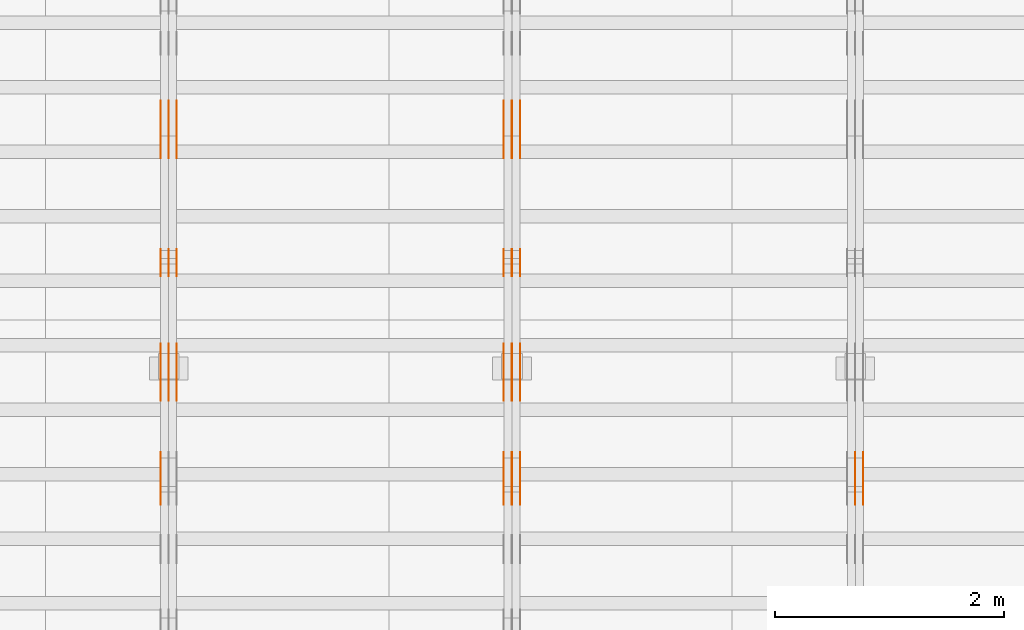
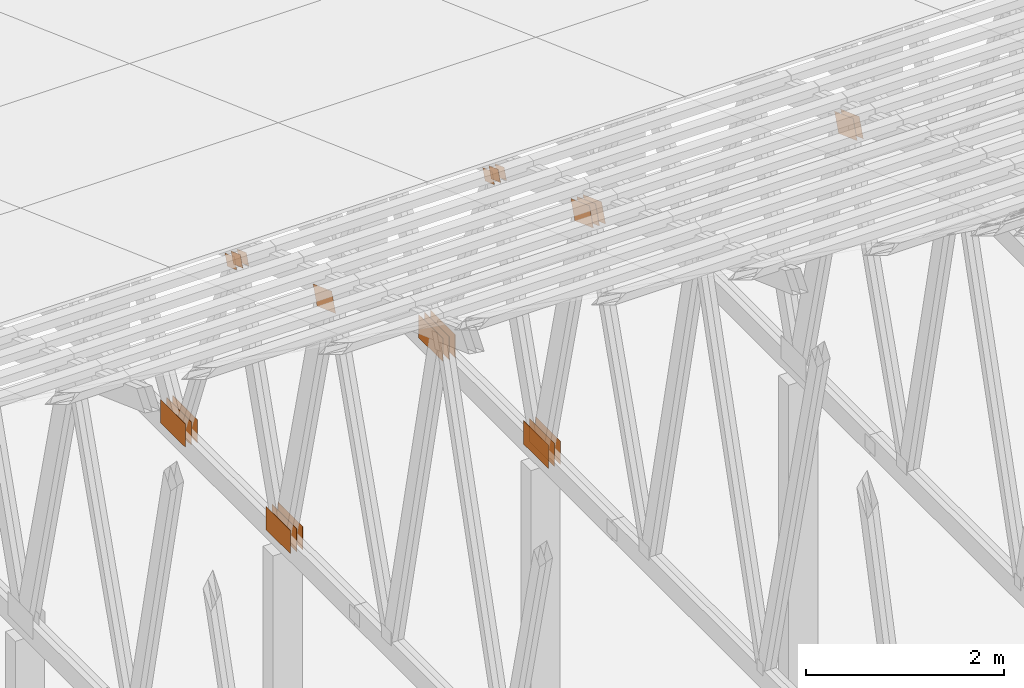
# One storey, part 121 of 189: 31 proxies.
"""IFC2X3 building model written with IfcOpenShell, lengths in millimetres."""

from ifc_helpers import new_model, entity, si_unit, converted_unit, derived_unit, direction, frame, origin, origin_2d_with_axis, place, context, subcontext, project, spatial, polyline, rectangle, outline, extrude, source, transform, mapped, material, type_object, type_shapes, element, save


model = new_model("IFC2X3")

# Units and contexts
model_context = context("Model", 3, precision=0.01, world=origin(), true_north=direction((6.12303176911189e-17, 1.0)))
body_context = subcontext(model_context, "Body", "Model", "MODEL_VIEW")
ifc_project = project(units=[si_unit("LENGTHUNIT", "METRE", prefix="MILLI"), si_unit("AREAUNIT", "SQUARE_METRE"), si_unit("VOLUMEUNIT", "CUBIC_METRE"), converted_unit("PLANEANGLEUNIT", "DEGREE", entity("IfcRatioMeasure", 0.0174532925199433), si_unit("PLANEANGLEUNIT", "RADIAN"), dimensions=[0, 0, 0, 0, 0, 0, 0]), si_unit("MASSUNIT", "GRAM", prefix="KILO"), derived_unit("MASSDENSITYUNIT", [(si_unit("MASSUNIT", "GRAM", prefix="KILO"), 1), (si_unit("LENGTHUNIT", "METRE"), -3)]), si_unit("TIMEUNIT", "SECOND"), si_unit("FREQUENCYUNIT", "HERTZ"), si_unit("THERMODYNAMICTEMPERATUREUNIT", "DEGREE_CELSIUS"), derived_unit("THERMALTRANSMITTANCEUNIT", [(si_unit("MASSUNIT", "GRAM", prefix="KILO"), 1), (si_unit("THERMODYNAMICTEMPERATUREUNIT", "KELVIN"), -1), (si_unit("TIMEUNIT", "SECOND"), -3)]), derived_unit("VOLUMETRICFLOWRATEUNIT", [(si_unit("LENGTHUNIT", "METRE"), 3), (si_unit("TIMEUNIT", "SECOND"), -1)]), si_unit("ELECTRICCURRENTUNIT", "AMPERE"), si_unit("ELECTRICVOLTAGEUNIT", "VOLT"), si_unit("POWERUNIT", "WATT"), si_unit("FORCEUNIT", "NEWTON"), si_unit("ILLUMINANCEUNIT", "LUX"), si_unit("LUMINOUSFLUXUNIT", "LUMEN"), si_unit("LUMINOUSINTENSITYUNIT", "CANDELA"), derived_unit("USERDEFINED", [(si_unit("MASSUNIT", "GRAM", prefix="KILO"), -1), (si_unit("LENGTHUNIT", "METRE"), -2), (si_unit("TIMEUNIT", "SECOND"), 3), (si_unit("LUMINOUSFLUXUNIT", "LUMEN"), 1)]), derived_unit("LINEARVELOCITYUNIT", [(si_unit("LENGTHUNIT", "METRE"), 1), (si_unit("TIMEUNIT", "SECOND"), -1)]), si_unit("PRESSUREUNIT", "PASCAL"), derived_unit("USERDEFINED", [(si_unit("LENGTHUNIT", "METRE"), -2), (si_unit("MASSUNIT", "GRAM", prefix="KILO"), 1), (si_unit("TIMEUNIT", "SECOND"), -2)])], contexts=[model_context])

# Site, building, storey
site_placement = place(None, origin())
site = spatial("IfcSite", under=ifc_project, at=site_placement, CompositionType="ELEMENT")
building_placement = place(site_placement, origin())
building = spatial("IfcBuilding", under=site, at=building_placement, CompositionType="ELEMENT")
storey_placement = place(building_placement, origin())
storey = spatial("IfcBuildingStorey", under=building, at=storey_placement, Name="Default", CompositionType="ELEMENT", Elevation=0.0)

# Proxies
ifc_material_1 = material(Name="IfcSurfaceStyle #123864")
building_element_proxy_type_1 = type_object("IfcBuildingElementProxyType", PredefinedType="NOTDEFINED", material=ifc_material_1)
shared_shape_1 = source(origin(), body_context, "Body", "SweptSolid", [
    extrude(outline(polyline([(-200.000344770935, -119.999765965113), (199.999582244654, -119.999765965113), (200.000344770935, 119.999765965113), (-199.999582244653, 119.999765965113), (-200.000344770935, -119.999765965113)])), frame((200.000344770935, 119.999990805307, 0.0), z_axis=(0.0, 0.0, 1.0), x_axis=(-1.0, 0.0, 0.0)), (0.0, 0.0, 1.0), 1.29999999999999),
])
type_shapes(building_element_proxy_type_1, [shared_shape_1])
proxy_1_placement = place(building_placement, frame((21301.3, 19620.1777846684, 3837.77137841443), z_axis=(-1.0, 0.0, 0.0), x_axis=(0.0, 0.939692620785908, -0.342020143325669)))
element("IfcBuildingElementProxy", 1, at=proxy_1_placement, inside=storey, type_object=building_element_proxy_type_1, material=ifc_material_1, context=body_context, shape_type="MappedRepresentation", body=[
    mapped(shared_shape_1, transform((0.0, 0.0, 0.0), scale=1.0)),
])
ifc_material_2 = material(Name="IfcSurfaceStyle #123807")
building_element_proxy_type_2 = type_object("IfcBuildingElementProxyType", PredefinedType="NOTDEFINED", material=ifc_material_2)
shared_shape_2 = source(origin(), body_context, "Body", "SweptSolid", [
    extrude(outline(polyline([(-200.000344770935, -119.999765965113), (199.999582244654, -119.999765965113), (200.000344770935, 119.999765965113), (-199.999582244653, 119.999765965113), (-200.000344770935, -119.999765965113)])), frame((200.000344770935, 119.999990805307, 0.0), z_axis=(0.0, 0.0, 1.0), x_axis=(-1.0, 0.0, 0.0)), (0.0, 0.0, 1.0), 1.29999999999997),
])
type_shapes(building_element_proxy_type_2, [shared_shape_2])
proxy_2_placement = place(building_placement, frame((21230.0, 19620.1777846684, 3837.77137841443), z_axis=(-1.0, 0.0, 0.0), x_axis=(0.0, 0.939692620785908, -0.342020143325669)))
element("IfcBuildingElementProxy", 2, at=proxy_2_placement, inside=storey, type_object=building_element_proxy_type_2, material=ifc_material_2, context=body_context, shape_type="MappedRepresentation", body=[
    mapped(shared_shape_2, transform((0.0, 0.0, 0.0), scale=1.0)),
])
ifc_material_3 = material(Name="IfcSurfaceStyle #108074")
building_element_proxy_type_3 = type_object("IfcBuildingElementProxyType", PredefinedType="NOTDEFINED", material=ifc_material_3)
shared_shape_3 = source(origin(), body_context, "Body", "SweptSolid", [
    extrude(outline(polyline([(-200.000344770935, -119.999765965113), (199.999582244654, -119.999765965113), (200.000344770935, 119.999765965113), (-199.999582244653, 119.999765965113), (-200.000344770935, -119.999765965113)])), frame((200.000344770935, 119.999990805307, 0.0), z_axis=(0.0, 0.0, 1.0), x_axis=(-1.0, 0.0, 0.0)), (0.0, 0.0, 1.0), 1.29999999999999),
])
type_shapes(building_element_proxy_type_3, [shared_shape_3])
proxy_3_placement = place(building_placement, frame((18301.3, 19620.1777846684, 3837.77137841443), z_axis=(-1.0, 0.0, 0.0), x_axis=(0.0, 0.939692620785908, -0.342020143325669)))
element("IfcBuildingElementProxy", 3, at=proxy_3_placement, inside=storey, type_object=building_element_proxy_type_3, material=ifc_material_3, context=body_context, shape_type="MappedRepresentation", body=[
    mapped(shared_shape_3, transform((0.0, 0.0, 0.0), scale=1.0)),
])
ifc_material_4 = material(Name="IfcSurfaceStyle #108017")
building_element_proxy_type_4 = type_object("IfcBuildingElementProxyType", PredefinedType="NOTDEFINED", material=ifc_material_4)
shared_shape_4 = source(origin(), body_context, "Body", "SweptSolid", [
    extrude(outline(polyline([(-200.000344770935, -119.999765965113), (199.999582244654, -119.999765965113), (200.000344770935, 119.999765965113), (-199.999582244653, 119.999765965113), (-200.000344770935, -119.999765965113)])), frame((200.000344770935, 119.999990805307, 0.0), z_axis=(0.0, 0.0, 1.0), x_axis=(-1.0, 0.0, 0.0)), (0.0, 0.0, 1.0), 1.29999999999997),
])
type_shapes(building_element_proxy_type_4, [shared_shape_4])
proxy_4_placement = place(building_placement, frame((18230.0, 19620.1777846684, 3837.77137841443), z_axis=(-1.0, 0.0, 0.0), x_axis=(0.0, 0.939692620785908, -0.342020143325669)))
element("IfcBuildingElementProxy", 4, at=proxy_4_placement, inside=storey, type_object=building_element_proxy_type_4, material=ifc_material_4, context=body_context, shape_type="MappedRepresentation", body=[
    mapped(shared_shape_4, transform((0.0, 0.0, 0.0), scale=1.0)),
])
ifc_material_5 = material(Name="IfcSurfaceStyle #107960")
building_element_proxy_type_5 = type_object("IfcBuildingElementProxyType", PredefinedType="NOTDEFINED", material=ifc_material_5)
shared_shape_5 = source(origin(), body_context, "Body", "SweptSolid", [
    extrude(outline(polyline([(-200.000344770935, -119.999765965113), (199.999582244654, -119.999765965113), (200.000344770935, 119.999765965113), (-199.999582244653, 119.999765965113), (-200.000344770935, -119.999765965113)])), frame((200.000344770935, 119.999990805307, 0.0), z_axis=(0.0, 0.0, 1.0), x_axis=(-1.0, 0.0, 0.0)), (0.0, 0.0, 1.0), 1.29999999999997),
])
type_shapes(building_element_proxy_type_5, [shared_shape_5])
proxy_5_placement = place(building_placement, frame((18231.3, 19620.1777846684, 3837.77137841443), z_axis=(-1.0, 0.0, 0.0), x_axis=(0.0, 0.939692620785908, -0.342020143325669)))
element("IfcBuildingElementProxy", 5, at=proxy_5_placement, inside=storey, type_object=building_element_proxy_type_5, material=ifc_material_5, context=body_context, shape_type="MappedRepresentation", body=[
    mapped(shared_shape_5, transform((0.0, 0.0, 0.0), scale=1.0)),
])
ifc_material_6 = material(Name="IfcSurfaceStyle #107903")
building_element_proxy_type_6 = type_object("IfcBuildingElementProxyType", PredefinedType="NOTDEFINED", material=ifc_material_6)
shared_shape_6 = source(origin(), body_context, "Body", "SweptSolid", [
    extrude(outline(polyline([(-200.000344770935, -119.999765965113), (199.999582244654, -119.999765965113), (200.000344770935, 119.999765965113), (-199.999582244653, 119.999765965113), (-200.000344770935, -119.999765965113)])), frame((200.000344770935, 119.999990805307, 0.0), z_axis=(0.0, 0.0, 1.0), x_axis=(-1.0, 0.0, 0.0)), (0.0, 0.0, 1.0), 1.29999999999998),
])
type_shapes(building_element_proxy_type_6, [shared_shape_6])
proxy_6_placement = place(building_placement, frame((18160.0, 19620.1777846684, 3837.77137841443), z_axis=(-1.0, 0.0, 0.0), x_axis=(0.0, 0.939692620785908, -0.342020143325669)))
element("IfcBuildingElementProxy", 6, at=proxy_6_placement, inside=storey, type_object=building_element_proxy_type_6, material=ifc_material_6, context=body_context, shape_type="MappedRepresentation", body=[
    mapped(shared_shape_6, transform((0.0, 0.0, 0.0), scale=1.0)),
])
ifc_material_7 = material(Name="IfcSurfaceStyle #107846")
building_element_proxy_type_7 = type_object("IfcBuildingElementProxyType", PredefinedType="NOTDEFINED", material=ifc_material_7)
shared_shape_7 = source(origin(), body_context, "Body", "SweptSolid", [
    extrude(rectangle(XDim=500.0, YDim=288.0, at=origin_2d_with_axis()), frame((250.0, 144.0, 0.0), z_axis=(0.0, 0.0, 1.0), x_axis=(-1.0, 0.0, 0.0)), (0.0, 0.0, 1.0), 1.29999999999998),
])
type_shapes(building_element_proxy_type_7, [shared_shape_7])
proxy_7_placement = place(building_placement, frame((18301.3, 20948.0908203125, 101.0), z_axis=(-1.0, 0.0, 0.0), x_axis=(0.0, -1.0, 0.0)))
element("IfcBuildingElementProxy", 7, at=proxy_7_placement, inside=storey, type_object=building_element_proxy_type_7, material=ifc_material_7, context=body_context, shape_type="MappedRepresentation", body=[
    mapped(shared_shape_7, transform((0.0, 0.0, 0.0), scale=1.0)),
])
ifc_material_8 = material(Name="IfcSurfaceStyle #107789")
building_element_proxy_type_8 = type_object("IfcBuildingElementProxyType", PredefinedType="NOTDEFINED", material=ifc_material_8)
shared_shape_8 = source(origin(), body_context, "Body", "SweptSolid", [
    extrude(rectangle(XDim=500.0, YDim=288.0, at=origin_2d_with_axis()), frame((250.0, 144.0, 0.0), z_axis=(0.0, 0.0, 1.0), x_axis=(-1.0, 0.0, 0.0)), (0.0, 0.0, 1.0), 1.29999999999997),
])
type_shapes(building_element_proxy_type_8, [shared_shape_8])
proxy_8_placement = place(building_placement, frame((18230.0, 20948.0908203125, 101.0), z_axis=(-1.0, 0.0, 0.0), x_axis=(0.0, -1.0, 0.0)))
element("IfcBuildingElementProxy", 8, at=proxy_8_placement, inside=storey, type_object=building_element_proxy_type_8, material=ifc_material_8, context=body_context, shape_type="MappedRepresentation", body=[
    mapped(shared_shape_8, transform((0.0, 0.0, 0.0), scale=1.0)),
])
ifc_material_9 = material(Name="IfcSurfaceStyle #107732")
building_element_proxy_type_9 = type_object("IfcBuildingElementProxyType", PredefinedType="NOTDEFINED", material=ifc_material_9)
shared_shape_9 = source(origin(), body_context, "Body", "SweptSolid", [
    extrude(rectangle(XDim=500.0, YDim=288.0, at=origin_2d_with_axis()), frame((250.0, 144.0, 0.0), z_axis=(0.0, 0.0, 1.0), x_axis=(-1.0, 0.0, 0.0)), (0.0, 0.0, 1.0), 1.29999999999997),
])
type_shapes(building_element_proxy_type_9, [shared_shape_9])
proxy_9_placement = place(building_placement, frame((18231.3, 20948.0908203125, 101.0), z_axis=(-1.0, 0.0, 0.0), x_axis=(0.0, -1.0, 0.0)))
element("IfcBuildingElementProxy", 9, at=proxy_9_placement, inside=storey, type_object=building_element_proxy_type_9, material=ifc_material_9, context=body_context, shape_type="MappedRepresentation", body=[
    mapped(shared_shape_9, transform((0.0, 0.0, 0.0), scale=1.0)),
])
ifc_material_10 = material(Name="IfcSurfaceStyle #107675")
building_element_proxy_type_10 = type_object("IfcBuildingElementProxyType", PredefinedType="NOTDEFINED", material=ifc_material_10)
shared_shape_10 = source(origin(), body_context, "Body", "SweptSolid", [
    extrude(rectangle(XDim=500.0, YDim=288.0, at=origin_2d_with_axis()), frame((250.0, 144.0, 0.0), z_axis=(0.0, 0.0, 1.0), x_axis=(-1.0, 0.0, 0.0)), (0.0, 0.0, 1.0), 1.29999999999997),
])
type_shapes(building_element_proxy_type_10, [shared_shape_10])
proxy_10_placement = place(building_placement, frame((18160.0, 20948.0908203125, 101.0), z_axis=(-1.0, 0.0, 0.0), x_axis=(0.0, -1.0, 0.0)))
element("IfcBuildingElementProxy", 10, at=proxy_10_placement, inside=storey, type_object=building_element_proxy_type_10, material=ifc_material_10, context=body_context, shape_type="MappedRepresentation", body=[
    mapped(shared_shape_10, transform((0.0, 0.0, 0.0), scale=1.0)),
])
ifc_material_11 = material(Name="IfcSurfaceStyle #107162")
building_element_proxy_type_11 = type_object("IfcBuildingElementProxyType", PredefinedType="NOTDEFINED", material=ifc_material_11)
shared_shape_11 = source(origin(), body_context, "Body", "SweptSolid", [
    extrude(outline(polyline([(-100.000279336925, -71.9999636698844), (100.000143005157, -71.9999636698844), (100.00004991978, 71.9999636698844), (-99.9999135880125, 71.9999636698845), (-100.000279336925, -71.9999636698844)])), frame((100.000143005157, 72.0001110824169, 0.0), z_axis=(0.0, 0.0, 1.0), x_axis=(-1.0, 0.0, 0.0)), (0.0, 0.0, 1.0), 1.3),
])
type_shapes(building_element_proxy_type_11, [shared_shape_11])
proxy_11_placement = place(building_placement, frame((18301.3, 21584.0819808932, 3071.51551466861), z_axis=(-1.0, 0.0, 0.0), x_axis=(0.0, 0.939692620785908, -0.342020143325669)))
element("IfcBuildingElementProxy", 11, at=proxy_11_placement, inside=storey, type_object=building_element_proxy_type_11, material=ifc_material_11, context=body_context, shape_type="MappedRepresentation", body=[
    mapped(shared_shape_11, transform((0.0, 0.0, 0.0), scale=1.0)),
])
ifc_material_12 = material(Name="IfcSurfaceStyle #107105")
building_element_proxy_type_12 = type_object("IfcBuildingElementProxyType", PredefinedType="NOTDEFINED", material=ifc_material_12)
shared_shape_12 = source(origin(), body_context, "Body", "SweptSolid", [
    extrude(outline(polyline([(-100.000279336925, -71.9999636698844), (100.000143005157, -71.9999636698844), (100.00004991978, 71.9999636698844), (-99.9999135880125, 71.9999636698845), (-100.000279336925, -71.9999636698844)])), frame((100.000143005157, 72.0001110824169, 0.0), z_axis=(0.0, 0.0, 1.0), x_axis=(-1.0, 0.0, 0.0)), (0.0, 0.0, 1.0), 1.29999999999998),
])
type_shapes(building_element_proxy_type_12, [shared_shape_12])
proxy_12_placement = place(building_placement, frame((18230.0, 21584.0819808932, 3071.51551466861), z_axis=(-1.0, 0.0, 0.0), x_axis=(0.0, 0.939692620785908, -0.342020143325669)))
element("IfcBuildingElementProxy", 12, at=proxy_12_placement, inside=storey, type_object=building_element_proxy_type_12, material=ifc_material_12, context=body_context, shape_type="MappedRepresentation", body=[
    mapped(shared_shape_12, transform((0.0, 0.0, 0.0), scale=1.0)),
])
ifc_material_13 = material(Name="IfcSurfaceStyle #107048")
building_element_proxy_type_13 = type_object("IfcBuildingElementProxyType", PredefinedType="NOTDEFINED", material=ifc_material_13)
shared_shape_13 = source(origin(), body_context, "Body", "SweptSolid", [
    extrude(outline(polyline([(-100.000279336925, -71.9999636698844), (100.000143005157, -71.9999636698844), (100.00004991978, 71.9999636698844), (-99.9999135880125, 71.9999636698845), (-100.000279336925, -71.9999636698844)])), frame((100.000143005157, 72.0001110824169, 0.0), z_axis=(0.0, 0.0, 1.0), x_axis=(-1.0, 0.0, 0.0)), (0.0, 0.0, 1.0), 1.29999999999998),
])
type_shapes(building_element_proxy_type_13, [shared_shape_13])
proxy_13_placement = place(building_placement, frame((18231.3, 21584.0819808932, 3071.51551466861), z_axis=(-1.0, 0.0, 0.0), x_axis=(0.0, 0.939692620785908, -0.342020143325669)))
element("IfcBuildingElementProxy", 13, at=proxy_13_placement, inside=storey, type_object=building_element_proxy_type_13, material=ifc_material_13, context=body_context, shape_type="MappedRepresentation", body=[
    mapped(shared_shape_13, transform((0.0, 0.0, 0.0), scale=1.0)),
])
ifc_material_14 = material(Name="IfcSurfaceStyle #106991")
building_element_proxy_type_14 = type_object("IfcBuildingElementProxyType", PredefinedType="NOTDEFINED", material=ifc_material_14)
shared_shape_14 = source(origin(), body_context, "Body", "SweptSolid", [
    extrude(outline(polyline([(-100.000279336925, -71.9999636698844), (100.000143005157, -71.9999636698844), (100.00004991978, 71.9999636698844), (-99.9999135880125, 71.9999636698845), (-100.000279336925, -71.9999636698844)])), frame((100.000143005157, 72.0001110824169, 0.0), z_axis=(0.0, 0.0, 1.0), x_axis=(-1.0, 0.0, 0.0)), (0.0, 0.0, 1.0), 1.29999999999999),
])
type_shapes(building_element_proxy_type_14, [shared_shape_14])
proxy_14_placement = place(building_placement, frame((18160.0, 21584.0819808932, 3071.51551466861), z_axis=(-1.0, 0.0, 0.0), x_axis=(0.0, 0.939692620785908, -0.342020143325669)))
element("IfcBuildingElementProxy", 14, at=proxy_14_placement, inside=storey, type_object=building_element_proxy_type_14, material=ifc_material_14, context=body_context, shape_type="MappedRepresentation", body=[
    mapped(shared_shape_14, transform((0.0, 0.0, 0.0), scale=1.0)),
])
ifc_material_15 = material(Name="IfcSurfaceStyle #106934")
building_element_proxy_type_15 = type_object("IfcBuildingElementProxyType", PredefinedType="NOTDEFINED", material=ifc_material_15)
shared_shape_15 = source(origin(), body_context, "Body", "SweptSolid", [
    extrude(rectangle(XDim=500.0, YDim=288.000007629395, at=origin_2d_with_axis()), frame((250.000021301719, 144.000006357829, 0.0), z_axis=(0.0, 0.0, 1.0), x_axis=(-1.0, 0.0, 0.0)), (0.0, 0.0, 1.0), 1.29999999999998),
])
type_shapes(building_element_proxy_type_15, [shared_shape_15])
proxy_15_placement = place(building_placement, frame((18301.3, 23069.1650603642, 127.333333333333), z_axis=(-1.0, 0.0, 0.0), x_axis=(0.0, -1.0, 0.0)))
element("IfcBuildingElementProxy", 15, at=proxy_15_placement, inside=storey, type_object=building_element_proxy_type_15, material=ifc_material_15, context=body_context, shape_type="MappedRepresentation", body=[
    mapped(shared_shape_15, transform((0.0, 0.0, 0.0), scale=1.0)),
])
ifc_material_16 = material(Name="IfcSurfaceStyle #106877")
building_element_proxy_type_16 = type_object("IfcBuildingElementProxyType", PredefinedType="NOTDEFINED", material=ifc_material_16)
shared_shape_16 = source(origin(), body_context, "Body", "SweptSolid", [
    extrude(rectangle(XDim=500.0, YDim=288.000007629395, at=origin_2d_with_axis()), frame((250.000021301719, 144.000006357829, 0.0), z_axis=(0.0, 0.0, 1.0), x_axis=(-1.0, 0.0, 0.0)), (0.0, 0.0, 1.0), 1.29999999999997),
])
type_shapes(building_element_proxy_type_16, [shared_shape_16])
proxy_16_placement = place(building_placement, frame((18230.0, 23069.1650603642, 127.333333333333), z_axis=(-1.0, 0.0, 0.0), x_axis=(0.0, -1.0, 0.0)))
element("IfcBuildingElementProxy", 16, at=proxy_16_placement, inside=storey, type_object=building_element_proxy_type_16, material=ifc_material_16, context=body_context, shape_type="MappedRepresentation", body=[
    mapped(shared_shape_16, transform((0.0, 0.0, 0.0), scale=1.0)),
])
ifc_material_17 = material(Name="IfcSurfaceStyle #106820")
building_element_proxy_type_17 = type_object("IfcBuildingElementProxyType", PredefinedType="NOTDEFINED", material=ifc_material_17)
shared_shape_17 = source(origin(), body_context, "Body", "SweptSolid", [
    extrude(rectangle(XDim=500.0, YDim=288.000007629395, at=origin_2d_with_axis()), frame((250.000021301719, 144.000006357829, 0.0), z_axis=(0.0, 0.0, 1.0), x_axis=(-1.0, 0.0, 0.0)), (0.0, 0.0, 1.0), 1.29999999999997),
])
type_shapes(building_element_proxy_type_17, [shared_shape_17])
proxy_17_placement = place(building_placement, frame((18231.3, 23069.1650603642, 127.333333333333), z_axis=(-1.0, 0.0, 0.0), x_axis=(0.0, -1.0, 0.0)))
element("IfcBuildingElementProxy", 17, at=proxy_17_placement, inside=storey, type_object=building_element_proxy_type_17, material=ifc_material_17, context=body_context, shape_type="MappedRepresentation", body=[
    mapped(shared_shape_17, transform((0.0, 0.0, 0.0), scale=1.0)),
])
ifc_material_18 = material(Name="IfcSurfaceStyle #106763")
building_element_proxy_type_18 = type_object("IfcBuildingElementProxyType", PredefinedType="NOTDEFINED", material=ifc_material_18)
shared_shape_18 = source(origin(), body_context, "Body", "SweptSolid", [
    extrude(rectangle(XDim=500.0, YDim=288.000007629395, at=origin_2d_with_axis()), frame((250.000021301719, 144.000006357829, 0.0), z_axis=(0.0, 0.0, 1.0), x_axis=(-1.0, 0.0, 0.0)), (0.0, 0.0, 1.0), 1.29999999999997),
])
type_shapes(building_element_proxy_type_18, [shared_shape_18])
proxy_18_placement = place(building_placement, frame((18160.0, 23069.1650603642, 127.333333333333), z_axis=(-1.0, 0.0, 0.0), x_axis=(0.0, -1.0, 0.0)))
element("IfcBuildingElementProxy", 18, at=proxy_18_placement, inside=storey, type_object=building_element_proxy_type_18, material=ifc_material_18, context=body_context, shape_type="MappedRepresentation", body=[
    mapped(shared_shape_18, transform((0.0, 0.0, 0.0), scale=1.0)),
])
ifc_material_19 = material(Name="IfcSurfaceStyle #92113")
building_element_proxy_type_19 = type_object("IfcBuildingElementProxyType", PredefinedType="NOTDEFINED", material=ifc_material_19)
shared_shape_19 = source(origin(), body_context, "Body", "SweptSolid", [
    extrude(outline(polyline([(-200.000344770935, -119.999765965113), (199.999582244654, -119.999765965113), (200.000344770935, 119.999765965113), (-199.999582244653, 119.999765965113), (-200.000344770935, -119.999765965113)])), frame((200.000344770935, 119.999990805307, 0.0), z_axis=(0.0, 0.0, 1.0), x_axis=(-1.0, 0.0, 0.0)), (0.0, 0.0, 1.0), 1.29999999999998),
])
type_shapes(building_element_proxy_type_19, [shared_shape_19])
proxy_19_placement = place(building_placement, frame((15160.0, 19620.1777846684, 3837.77137841443), z_axis=(-1.0, 0.0, 0.0), x_axis=(0.0, 0.939692620785908, -0.342020143325669)))
element("IfcBuildingElementProxy", 19, at=proxy_19_placement, inside=storey, type_object=building_element_proxy_type_19, material=ifc_material_19, context=body_context, shape_type="MappedRepresentation", body=[
    mapped(shared_shape_19, transform((0.0, 0.0, 0.0), scale=1.0)),
])
ifc_material_20 = material(Name="IfcSurfaceStyle #92056")
building_element_proxy_type_20 = type_object("IfcBuildingElementProxyType", PredefinedType="NOTDEFINED", material=ifc_material_20)
shared_shape_20 = source(origin(), body_context, "Body", "SweptSolid", [
    extrude(rectangle(XDim=500.0, YDim=288.0, at=origin_2d_with_axis()), frame((250.0, 144.0, 0.0), z_axis=(0.0, 0.0, 1.0), x_axis=(-1.0, 0.0, 0.0)), (0.0, 0.0, 1.0), 1.29999999999998),
])
type_shapes(building_element_proxy_type_20, [shared_shape_20])
proxy_20_placement = place(building_placement, frame((15301.3, 20948.0908203125, 101.0), z_axis=(-1.0, 0.0, 0.0), x_axis=(0.0, -1.0, 0.0)))
element("IfcBuildingElementProxy", 20, at=proxy_20_placement, inside=storey, type_object=building_element_proxy_type_20, material=ifc_material_20, context=body_context, shape_type="MappedRepresentation", body=[
    mapped(shared_shape_20, transform((0.0, 0.0, 0.0), scale=1.0)),
])
ifc_material_21 = material(Name="IfcSurfaceStyle #91999")
building_element_proxy_type_21 = type_object("IfcBuildingElementProxyType", PredefinedType="NOTDEFINED", material=ifc_material_21)
shared_shape_21 = source(origin(), body_context, "Body", "SweptSolid", [
    extrude(rectangle(XDim=500.0, YDim=288.0, at=origin_2d_with_axis()), frame((250.0, 144.0, 0.0), z_axis=(0.0, 0.0, 1.0), x_axis=(-1.0, 0.0, 0.0)), (0.0, 0.0, 1.0), 1.29999999999997),
])
type_shapes(building_element_proxy_type_21, [shared_shape_21])
proxy_21_placement = place(building_placement, frame((15230.0, 20948.0908203125, 101.0), z_axis=(-1.0, 0.0, 0.0), x_axis=(0.0, -1.0, 0.0)))
element("IfcBuildingElementProxy", 21, at=proxy_21_placement, inside=storey, type_object=building_element_proxy_type_21, material=ifc_material_21, context=body_context, shape_type="MappedRepresentation", body=[
    mapped(shared_shape_21, transform((0.0, 0.0, 0.0), scale=1.0)),
])
ifc_material_22 = material(Name="IfcSurfaceStyle #91942")
building_element_proxy_type_22 = type_object("IfcBuildingElementProxyType", PredefinedType="NOTDEFINED", material=ifc_material_22)
shared_shape_22 = source(origin(), body_context, "Body", "SweptSolid", [
    extrude(rectangle(XDim=500.0, YDim=288.0, at=origin_2d_with_axis()), frame((250.0, 144.0, 0.0), z_axis=(0.0, 0.0, 1.0), x_axis=(-1.0, 0.0, 0.0)), (0.0, 0.0, 1.0), 1.29999999999997),
])
type_shapes(building_element_proxy_type_22, [shared_shape_22])
proxy_22_placement = place(building_placement, frame((15231.3, 20948.0908203125, 101.0), z_axis=(-1.0, 0.0, 0.0), x_axis=(0.0, -1.0, 0.0)))
element("IfcBuildingElementProxy", 22, at=proxy_22_placement, inside=storey, type_object=building_element_proxy_type_22, material=ifc_material_22, context=body_context, shape_type="MappedRepresentation", body=[
    mapped(shared_shape_22, transform((0.0, 0.0, 0.0), scale=1.0)),
])
ifc_material_23 = material(Name="IfcSurfaceStyle #91885")
building_element_proxy_type_23 = type_object("IfcBuildingElementProxyType", PredefinedType="NOTDEFINED", material=ifc_material_23)
shared_shape_23 = source(origin(), body_context, "Body", "SweptSolid", [
    extrude(rectangle(XDim=500.0, YDim=288.0, at=origin_2d_with_axis()), frame((250.0, 144.0, 0.0), z_axis=(0.0, 0.0, 1.0), x_axis=(-1.0, 0.0, 0.0)), (0.0, 0.0, 1.0), 1.29999999999997),
])
type_shapes(building_element_proxy_type_23, [shared_shape_23])
proxy_23_placement = place(building_placement, frame((15160.0, 20948.0908203125, 101.0), z_axis=(-1.0, 0.0, 0.0), x_axis=(0.0, -1.0, 0.0)))
element("IfcBuildingElementProxy", 23, at=proxy_23_placement, inside=storey, type_object=building_element_proxy_type_23, material=ifc_material_23, context=body_context, shape_type="MappedRepresentation", body=[
    mapped(shared_shape_23, transform((0.0, 0.0, 0.0), scale=1.0)),
])
ifc_material_24 = material(Name="IfcSurfaceStyle #91372")
building_element_proxy_type_24 = type_object("IfcBuildingElementProxyType", PredefinedType="NOTDEFINED", material=ifc_material_24)
shared_shape_24 = source(origin(), body_context, "Body", "SweptSolid", [
    extrude(outline(polyline([(-100.000279336925, -71.9999636698844), (100.000143005157, -71.9999636698844), (100.00004991978, 71.9999636698844), (-99.9999135880125, 71.9999636698845), (-100.000279336925, -71.9999636698844)])), frame((100.000143005157, 72.0001110824169, 0.0), z_axis=(0.0, 0.0, 1.0), x_axis=(-1.0, 0.0, 0.0)), (0.0, 0.0, 1.0), 1.3),
])
type_shapes(building_element_proxy_type_24, [shared_shape_24])
proxy_24_placement = place(building_placement, frame((15301.3, 21584.0819808932, 3071.51551466861), z_axis=(-1.0, 0.0, 0.0), x_axis=(0.0, 0.939692620785908, -0.342020143325669)))
element("IfcBuildingElementProxy", 24, at=proxy_24_placement, inside=storey, type_object=building_element_proxy_type_24, material=ifc_material_24, context=body_context, shape_type="MappedRepresentation", body=[
    mapped(shared_shape_24, transform((0.0, 0.0, 0.0), scale=1.0)),
])
ifc_material_25 = material(Name="IfcSurfaceStyle #91315")
building_element_proxy_type_25 = type_object("IfcBuildingElementProxyType", PredefinedType="NOTDEFINED", material=ifc_material_25)
shared_shape_25 = source(origin(), body_context, "Body", "SweptSolid", [
    extrude(outline(polyline([(-100.000279336925, -71.9999636698844), (100.000143005157, -71.9999636698844), (100.00004991978, 71.9999636698844), (-99.9999135880125, 71.9999636698845), (-100.000279336925, -71.9999636698844)])), frame((100.000143005157, 72.0001110824169, 0.0), z_axis=(0.0, 0.0, 1.0), x_axis=(-1.0, 0.0, 0.0)), (0.0, 0.0, 1.0), 1.29999999999998),
])
type_shapes(building_element_proxy_type_25, [shared_shape_25])
proxy_25_placement = place(building_placement, frame((15230.0, 21584.0819808932, 3071.51551466861), z_axis=(-1.0, 0.0, 0.0), x_axis=(0.0, 0.939692620785908, -0.342020143325669)))
element("IfcBuildingElementProxy", 25, at=proxy_25_placement, inside=storey, type_object=building_element_proxy_type_25, material=ifc_material_25, context=body_context, shape_type="MappedRepresentation", body=[
    mapped(shared_shape_25, transform((0.0, 0.0, 0.0), scale=1.0)),
])
ifc_material_26 = material(Name="IfcSurfaceStyle #91258")
building_element_proxy_type_26 = type_object("IfcBuildingElementProxyType", PredefinedType="NOTDEFINED", material=ifc_material_26)
shared_shape_26 = source(origin(), body_context, "Body", "SweptSolid", [
    extrude(outline(polyline([(-100.000279336925, -71.9999636698844), (100.000143005157, -71.9999636698844), (100.00004991978, 71.9999636698844), (-99.9999135880125, 71.9999636698845), (-100.000279336925, -71.9999636698844)])), frame((100.000143005157, 72.0001110824169, 0.0), z_axis=(0.0, 0.0, 1.0), x_axis=(-1.0, 0.0, 0.0)), (0.0, 0.0, 1.0), 1.29999999999998),
])
type_shapes(building_element_proxy_type_26, [shared_shape_26])
proxy_26_placement = place(building_placement, frame((15231.3, 21584.0819808932, 3071.51551466861), z_axis=(-1.0, 0.0, 0.0), x_axis=(0.0, 0.939692620785908, -0.342020143325669)))
element("IfcBuildingElementProxy", 26, at=proxy_26_placement, inside=storey, type_object=building_element_proxy_type_26, material=ifc_material_26, context=body_context, shape_type="MappedRepresentation", body=[
    mapped(shared_shape_26, transform((0.0, 0.0, 0.0), scale=1.0)),
])
ifc_material_27 = material(Name="IfcSurfaceStyle #91201")
building_element_proxy_type_27 = type_object("IfcBuildingElementProxyType", PredefinedType="NOTDEFINED", material=ifc_material_27)
shared_shape_27 = source(origin(), body_context, "Body", "SweptSolid", [
    extrude(outline(polyline([(-100.000279336925, -71.9999636698844), (100.000143005157, -71.9999636698844), (100.00004991978, 71.9999636698844), (-99.9999135880125, 71.9999636698845), (-100.000279336925, -71.9999636698844)])), frame((100.000143005157, 72.0001110824169, 0.0), z_axis=(0.0, 0.0, 1.0), x_axis=(-1.0, 0.0, 0.0)), (0.0, 0.0, 1.0), 1.29999999999999),
])
type_shapes(building_element_proxy_type_27, [shared_shape_27])
proxy_27_placement = place(building_placement, frame((15160.0, 21584.0819808932, 3071.51551466861), z_axis=(-1.0, 0.0, 0.0), x_axis=(0.0, 0.939692620785908, -0.342020143325669)))
element("IfcBuildingElementProxy", 27, at=proxy_27_placement, inside=storey, type_object=building_element_proxy_type_27, material=ifc_material_27, context=body_context, shape_type="MappedRepresentation", body=[
    mapped(shared_shape_27, transform((0.0, 0.0, 0.0), scale=1.0)),
])
ifc_material_28 = material(Name="IfcSurfaceStyle #91144")
building_element_proxy_type_28 = type_object("IfcBuildingElementProxyType", PredefinedType="NOTDEFINED", material=ifc_material_28)
shared_shape_28 = source(origin(), body_context, "Body", "SweptSolid", [
    extrude(rectangle(XDim=500.0, YDim=288.000007629395, at=origin_2d_with_axis()), frame((250.000021301719, 144.000006357829, 0.0), z_axis=(0.0, 0.0, 1.0), x_axis=(-1.0, 0.0, 0.0)), (0.0, 0.0, 1.0), 1.29999999999998),
])
type_shapes(building_element_proxy_type_28, [shared_shape_28])
proxy_28_placement = place(building_placement, frame((15301.3, 23069.1650603642, 127.333333333333), z_axis=(-1.0, 0.0, 0.0), x_axis=(0.0, -1.0, 0.0)))
element("IfcBuildingElementProxy", 28, at=proxy_28_placement, inside=storey, type_object=building_element_proxy_type_28, material=ifc_material_28, context=body_context, shape_type="MappedRepresentation", body=[
    mapped(shared_shape_28, transform((0.0, 0.0, 0.0), scale=1.0)),
])
ifc_material_29 = material(Name="IfcSurfaceStyle #91087")
building_element_proxy_type_29 = type_object("IfcBuildingElementProxyType", PredefinedType="NOTDEFINED", material=ifc_material_29)
shared_shape_29 = source(origin(), body_context, "Body", "SweptSolid", [
    extrude(rectangle(XDim=500.0, YDim=288.000007629395, at=origin_2d_with_axis()), frame((250.000021301719, 144.000006357829, 0.0), z_axis=(0.0, 0.0, 1.0), x_axis=(-1.0, 0.0, 0.0)), (0.0, 0.0, 1.0), 1.29999999999997),
])
type_shapes(building_element_proxy_type_29, [shared_shape_29])
proxy_29_placement = place(building_placement, frame((15230.0, 23069.1650603642, 127.333333333333), z_axis=(-1.0, 0.0, 0.0), x_axis=(0.0, -1.0, 0.0)))
element("IfcBuildingElementProxy", 29, at=proxy_29_placement, inside=storey, type_object=building_element_proxy_type_29, material=ifc_material_29, context=body_context, shape_type="MappedRepresentation", body=[
    mapped(shared_shape_29, transform((0.0, 0.0, 0.0), scale=1.0)),
])
ifc_material_30 = material(Name="IfcSurfaceStyle #91030")
building_element_proxy_type_30 = type_object("IfcBuildingElementProxyType", PredefinedType="NOTDEFINED", material=ifc_material_30)
shared_shape_30 = source(origin(), body_context, "Body", "SweptSolid", [
    extrude(rectangle(XDim=500.0, YDim=288.000007629395, at=origin_2d_with_axis()), frame((250.000021301719, 144.000006357829, 0.0), z_axis=(0.0, 0.0, 1.0), x_axis=(-1.0, 0.0, 0.0)), (0.0, 0.0, 1.0), 1.29999999999997),
])
type_shapes(building_element_proxy_type_30, [shared_shape_30])
proxy_30_placement = place(building_placement, frame((15231.3, 23069.1650603642, 127.333333333333), z_axis=(-1.0, 0.0, 0.0), x_axis=(0.0, -1.0, 0.0)))
element("IfcBuildingElementProxy", 30, at=proxy_30_placement, inside=storey, type_object=building_element_proxy_type_30, material=ifc_material_30, context=body_context, shape_type="MappedRepresentation", body=[
    mapped(shared_shape_30, transform((0.0, 0.0, 0.0), scale=1.0)),
])
ifc_material_31 = material(Name="IfcSurfaceStyle #90973")
building_element_proxy_type_31 = type_object("IfcBuildingElementProxyType", PredefinedType="NOTDEFINED", material=ifc_material_31)
shared_shape_31 = source(origin(), body_context, "Body", "SweptSolid", [
    extrude(rectangle(XDim=500.0, YDim=288.000007629395, at=origin_2d_with_axis()), frame((250.000021301719, 144.000006357829, 0.0), z_axis=(0.0, 0.0, 1.0), x_axis=(-1.0, 0.0, 0.0)), (0.0, 0.0, 1.0), 1.29999999999997),
])
type_shapes(building_element_proxy_type_31, [shared_shape_31])
proxy_31_placement = place(building_placement, frame((15160.0, 23069.1650603642, 127.333333333333), z_axis=(-1.0, 0.0, 0.0), x_axis=(0.0, -1.0, 0.0)))
element("IfcBuildingElementProxy", 31, at=proxy_31_placement, inside=storey, type_object=building_element_proxy_type_31, material=ifc_material_31, context=body_context, shape_type="MappedRepresentation", body=[
    mapped(shared_shape_31, transform((0.0, 0.0, 0.0), scale=1.0)),
])

save(model, "model.ifc")
